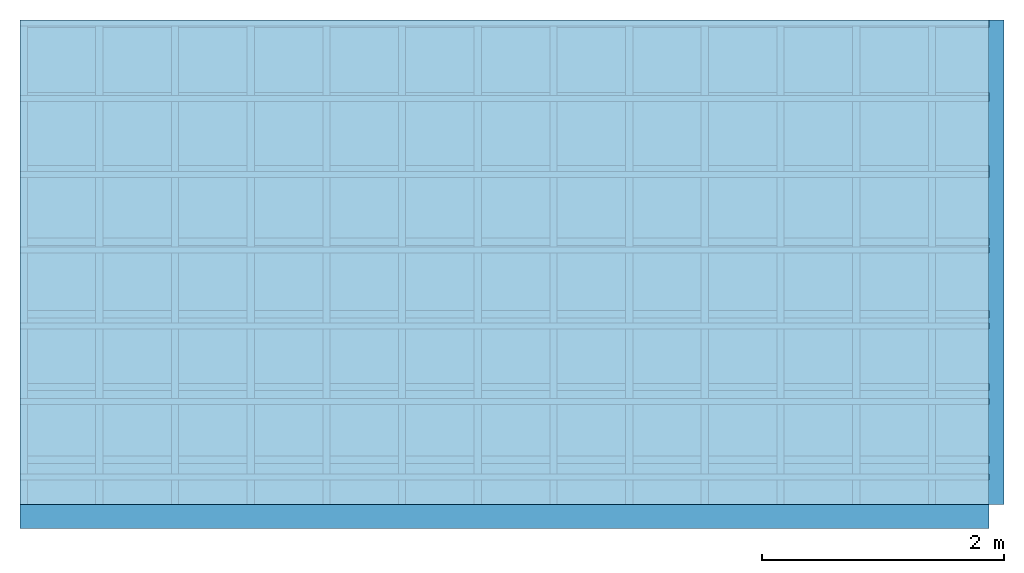
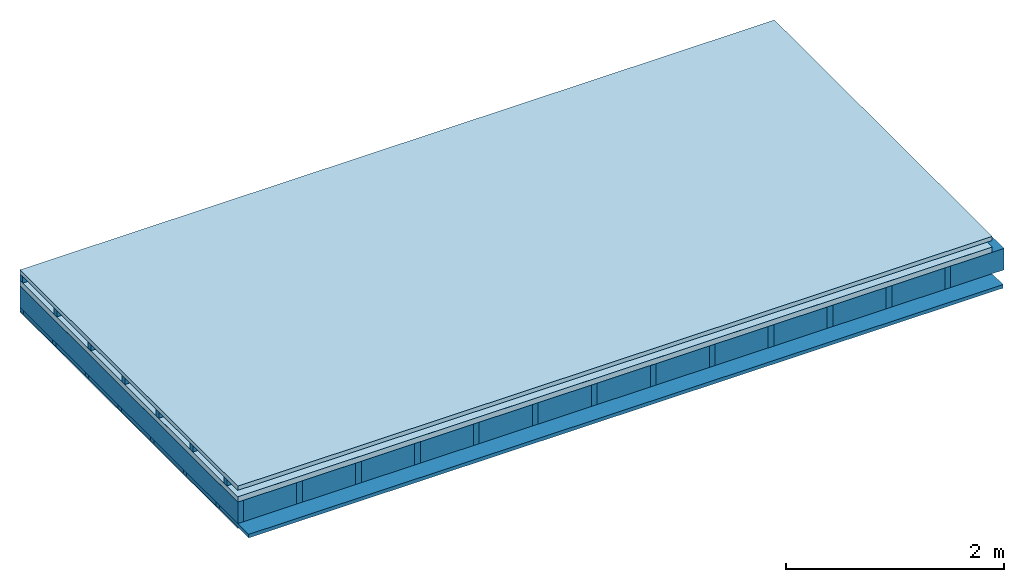
# One storey: 5 members, 4 plates, 1 element without a shape of its own.
"""IFC4 building model written with IfcOpenShell, lengths in metres."""

from ifc_helpers import new_model, si_unit, derived_unit, direction, frame, frame_2d, origin, origin_with_axes, place, context, project, spatial, rectangle, extrude, material, layer, layer_set, type_object, element, aggregate, save


model = new_model("IFC4")

# Units and contexts
plan_context = context("Plan", 3, precision=1e-05, world=origin(), true_north=direction((0.0, 1.0)))
model_context = context("Model", 3, precision=1e-05, world=origin(), true_north=direction((0.0, 1.0)))
ifc_project = project(units=[si_unit("LENGTHUNIT", "METRE"), derived_unit("SOUNDPRESSUREUNIT", [(si_unit("PRESSUREUNIT", "PASCAL", prefix="MICRO"), 0)]), si_unit("ENERGYUNIT", "JOULE", prefix="MEGA"), si_unit("MASSUNIT", "GRAM", prefix="KILO"), derived_unit("THERMALTRANSMITTANCEUNIT", [(si_unit("POWERUNIT", "WATT"), 1), (si_unit("AREAUNIT", "SQUARE_METRE"), -1), (si_unit("THERMODYNAMICTEMPERATUREUNIT", "KELVIN"), -1)]), derived_unit("AREADENSITYUNIT", [(si_unit("MASSUNIT", "GRAM", prefix="KILO"), 1), (si_unit("AREAUNIT", "SQUARE_METRE"), -1)]), derived_unit("USERDEFINED", [(si_unit("ENERGYUNIT", "JOULE", prefix="MEGA"), 1), (si_unit("AREAUNIT", "SQUARE_METRE"), -1)])], contexts=[plan_context, model_context])

# Site, building, storey
site = spatial("IfcSite", under=ifc_project)
building_placement = place(None, origin())
building = spatial("IfcBuilding", under=site, at=building_placement)
storey_placement = place(building_placement, origin())
storey = spatial("IfcBuildingStorey", under=building, at=storey_placement)

# Slab, members, plates
ifc_material_1 = material(Name="Roof tiles", Category="03.015")
ifc_layer_1 = layer(ifc_material_1, 0.047, Name="Roofing")
ifc_layer_2 = layer(None, 0.072, Name="Battens / profiles")
ifc_material_2 = material(Name="Roofing underlay", Category="09.008")
ifc_layer_3 = layer(ifc_material_2, 0.00018, Name="Under the roof")
ifc_material_3 = material(Category="10.009")
ifc_layer_4 = layer(ifc_material_3, 0.06, Name="Exterior insulation layer 1")
ifc_material_4 = material(Name="no composite action")
ifc_layer_5 = layer(ifc_material_4, 0.0, Name="Bond")
ifc_layer_6 = layer(None, 0.24, Name="Supporting structure")
ifc_material_5 = material(Name="of the art")
ifc_layer_7 = layer(ifc_material_5, 0.0, Name="Bond")
ifc_layer_8 = layer(None, 0.04, Name="Battens / profiles")
ifc_material_6 = material(Category="03.007")
ifc_layer_9 = layer(ifc_material_6, 0.015, Name="Covering below 1st layer")
ifc_material_7 = material(Name="Glued joints")
ifc_layer_10 = layer(ifc_material_7, 0.0, Name="Surface below")
ifc_layer_set = layer_set([ifc_layer_1, ifc_layer_2, ifc_layer_3, ifc_layer_4, ifc_layer_5, ifc_layer_6, ifc_layer_7, ifc_layer_8, ifc_layer_9, ifc_layer_10])
slab_type = type_object("IfcSlabType", Name="E0120", PredefinedType="NOTDEFINED", material=ifc_layer_set)
slab_placement = place(None, frame((0.0, 0.0, 0.0), z_axis=(0.0, 0.0, -1.0), x_axis=(1.0, 0.0, 0.0)))
slab = element("IfcSlab", 1, at=slab_placement, inside=storey, type_object=slab_type, material=ifc_layer_set, Name="Slab #1")
ifc_material_8 = material()
member_1_placement = place(slab_placement, origin())
member_1 = element("IfcMember", 2, at=member_1_placement, material=ifc_material_8, Name="Battens / profiles", context=plan_context, shape_type="SweptSolid", body=[
    extrude(rectangle(XDim=0.05, YDim=0.072, at=frame_2d((0.025, 0.036), x_axis=(1.0, 0.0))), frame((0.0, 0.0, 0.047), z_axis=(1.0, 0.0, 0.0), x_axis=(0.0, 1.0, 0.0)), (0.0, 0.0, 1.0), 8.0),
    extrude(rectangle(XDim=0.05, YDim=0.072, at=frame_2d((0.025, 0.036), x_axis=(1.0, 0.0))), frame((0.0, 0.625, 0.047), z_axis=(1.0, 0.0, 0.0), x_axis=(0.0, 1.0, 0.0)), (0.0, 0.0, 1.0), 8.0),
    extrude(rectangle(XDim=0.05, YDim=0.072, at=frame_2d((0.025, 0.036), x_axis=(1.0, 0.0))), frame((0.0, 1.25, 0.047), z_axis=(1.0, 0.0, 0.0), x_axis=(0.0, 1.0, 0.0)), (0.0, 0.0, 1.0), 8.0),
    extrude(rectangle(XDim=0.05, YDim=0.072, at=frame_2d((0.025, 0.036), x_axis=(1.0, 0.0))), frame((0.0, 1.875, 0.047), z_axis=(1.0, 0.0, 0.0), x_axis=(0.0, 1.0, 0.0)), (0.0, 0.0, 1.0), 8.0),
    extrude(rectangle(XDim=0.05, YDim=0.072, at=frame_2d((0.025, 0.036), x_axis=(1.0, 0.0))), frame((0.0, 2.5, 0.047), z_axis=(1.0, 0.0, 0.0), x_axis=(0.0, 1.0, 0.0)), (0.0, 0.0, 1.0), 8.0),
    extrude(rectangle(XDim=0.05, YDim=0.072, at=frame_2d((0.025, 0.036), x_axis=(1.0, 0.0))), frame((0.0, 3.125, 0.047), z_axis=(1.0, 0.0, 0.0), x_axis=(0.0, 1.0, 0.0)), (0.0, 0.0, 1.0), 8.0),
    extrude(rectangle(XDim=0.05, YDim=0.072, at=frame_2d((0.025, 0.036), x_axis=(1.0, 0.0))), frame((0.0, 3.75, 0.047), z_axis=(1.0, 0.0, 0.0), x_axis=(0.0, 1.0, 0.0)), (0.0, 0.0, 1.0), 8.0),
])
ifc_material_9 = material()
member_2_placement = place(slab_placement, origin())
member_2 = element("IfcMember", 3, at=member_2_placement, material=ifc_material_9, Name="Supporting structure", context=plan_context, shape_type="SweptSolid", body=[
    extrude(rectangle(XDim=0.06, YDim=0.24, at=frame_2d((0.03, 0.12), x_axis=(1.0, 0.0))), frame((0.0, 4.0, 0.17918), z_axis=(0.0, -1.0, 0.0), x_axis=(1.0, 0.0, 0.0)), (0.0, 0.0, 1.0), 4.0),
    extrude(rectangle(XDim=0.06, YDim=0.24, at=frame_2d((0.03, 0.12), x_axis=(1.0, 0.0))), frame((0.625, 4.0, 0.17918), z_axis=(0.0, -1.0, 0.0), x_axis=(1.0, 0.0, 0.0)), (0.0, 0.0, 1.0), 4.0),
    extrude(rectangle(XDim=0.06, YDim=0.24, at=frame_2d((0.03, 0.12), x_axis=(1.0, 0.0))), frame((1.25, 4.0, 0.17918), z_axis=(0.0, -1.0, 0.0), x_axis=(1.0, 0.0, 0.0)), (0.0, 0.0, 1.0), 4.0),
    extrude(rectangle(XDim=0.06, YDim=0.24, at=frame_2d((0.03, 0.12), x_axis=(1.0, 0.0))), frame((1.875, 4.0, 0.17918), z_axis=(0.0, -1.0, 0.0), x_axis=(1.0, 0.0, 0.0)), (0.0, 0.0, 1.0), 4.0),
    extrude(rectangle(XDim=0.06, YDim=0.24, at=frame_2d((0.03, 0.12), x_axis=(1.0, 0.0))), frame((2.5, 4.0, 0.17918), z_axis=(0.0, -1.0, 0.0), x_axis=(1.0, 0.0, 0.0)), (0.0, 0.0, 1.0), 4.0),
    extrude(rectangle(XDim=0.06, YDim=0.24, at=frame_2d((0.03, 0.12), x_axis=(1.0, 0.0))), frame((3.125, 4.0, 0.17918), z_axis=(0.0, -1.0, 0.0), x_axis=(1.0, 0.0, 0.0)), (0.0, 0.0, 1.0), 4.0),
    extrude(rectangle(XDim=0.06, YDim=0.24, at=frame_2d((0.03, 0.12), x_axis=(1.0, 0.0))), frame((3.75, 4.0, 0.17918), z_axis=(0.0, -1.0, 0.0), x_axis=(1.0, 0.0, 0.0)), (0.0, 0.0, 1.0), 4.0),
    extrude(rectangle(XDim=0.06, YDim=0.24, at=frame_2d((0.03, 0.12), x_axis=(1.0, 0.0))), frame((4.375, 4.0, 0.17918), z_axis=(0.0, -1.0, 0.0), x_axis=(1.0, 0.0, 0.0)), (0.0, 0.0, 1.0), 4.0),
    extrude(rectangle(XDim=0.06, YDim=0.24, at=frame_2d((0.03, 0.12), x_axis=(1.0, 0.0))), frame((5.0, 4.0, 0.17918), z_axis=(0.0, -1.0, 0.0), x_axis=(1.0, 0.0, 0.0)), (0.0, 0.0, 1.0), 4.0),
    extrude(rectangle(XDim=0.06, YDim=0.24, at=frame_2d((0.03, 0.12), x_axis=(1.0, 0.0))), frame((5.625, 4.0, 0.17918), z_axis=(0.0, -1.0, 0.0), x_axis=(1.0, 0.0, 0.0)), (0.0, 0.0, 1.0), 4.0),
    extrude(rectangle(XDim=0.06, YDim=0.24, at=frame_2d((0.03, 0.12), x_axis=(1.0, 0.0))), frame((6.25, 4.0, 0.17918), z_axis=(0.0, -1.0, 0.0), x_axis=(1.0, 0.0, 0.0)), (0.0, 0.0, 1.0), 4.0),
    extrude(rectangle(XDim=0.06, YDim=0.24, at=frame_2d((0.03, 0.12), x_axis=(1.0, 0.0))), frame((6.875, 4.0, 0.17918), z_axis=(0.0, -1.0, 0.0), x_axis=(1.0, 0.0, 0.0)), (0.0, 0.0, 1.0), 4.0),
    extrude(rectangle(XDim=0.06, YDim=0.24, at=frame_2d((0.03, 0.12), x_axis=(1.0, 0.0))), frame((7.5, 4.0, 0.17918), z_axis=(0.0, -1.0, 0.0), x_axis=(1.0, 0.0, 0.0)), (0.0, 0.0, 1.0), 4.0),
])
ifc_material_10 = material()
member_3_placement = place(slab_placement, origin())
member_3 = element("IfcMember", 4, at=member_3_placement, material=ifc_material_10, Name="Cavity", context=plan_context, shape_type="SweptSolid", body=[
    extrude(rectangle(XDim=0.565, YDim=0.24, at=frame_2d((0.2825, 0.12), x_axis=(1.0, 0.0))), frame((0.06, 4.0, 0.17918), z_axis=(0.0, -1.0, 0.0), x_axis=(1.0, 0.0, 0.0)), (0.0, 0.0, 1.0), 4.0),
    extrude(rectangle(XDim=0.565, YDim=0.24, at=frame_2d((0.2825, 0.12), x_axis=(1.0, 0.0))), frame((0.685, 4.0, 0.17918), z_axis=(0.0, -1.0, 0.0), x_axis=(1.0, 0.0, 0.0)), (0.0, 0.0, 1.0), 4.0),
    extrude(rectangle(XDim=0.565, YDim=0.24, at=frame_2d((0.2825, 0.12), x_axis=(1.0, 0.0))), frame((1.31, 4.0, 0.17918), z_axis=(0.0, -1.0, 0.0), x_axis=(1.0, 0.0, 0.0)), (0.0, 0.0, 1.0), 4.0),
    extrude(rectangle(XDim=0.565, YDim=0.24, at=frame_2d((0.2825, 0.12), x_axis=(1.0, 0.0))), frame((1.935, 4.0, 0.17918), z_axis=(0.0, -1.0, 0.0), x_axis=(1.0, 0.0, 0.0)), (0.0, 0.0, 1.0), 4.0),
    extrude(rectangle(XDim=0.565, YDim=0.24, at=frame_2d((0.2825, 0.12), x_axis=(1.0, 0.0))), frame((2.56, 4.0, 0.17918), z_axis=(0.0, -1.0, 0.0), x_axis=(1.0, 0.0, 0.0)), (0.0, 0.0, 1.0), 4.0),
    extrude(rectangle(XDim=0.565, YDim=0.24, at=frame_2d((0.2825, 0.12), x_axis=(1.0, 0.0))), frame((3.185, 4.0, 0.17918), z_axis=(0.0, -1.0, 0.0), x_axis=(1.0, 0.0, 0.0)), (0.0, 0.0, 1.0), 4.0),
    extrude(rectangle(XDim=0.565, YDim=0.24, at=frame_2d((0.2825, 0.12), x_axis=(1.0, 0.0))), frame((3.81, 4.0, 0.17918), z_axis=(0.0, -1.0, 0.0), x_axis=(1.0, 0.0, 0.0)), (0.0, 0.0, 1.0), 4.0),
    extrude(rectangle(XDim=0.565, YDim=0.24, at=frame_2d((0.2825, 0.12), x_axis=(1.0, 0.0))), frame((4.435, 4.0, 0.17918), z_axis=(0.0, -1.0, 0.0), x_axis=(1.0, 0.0, 0.0)), (0.0, 0.0, 1.0), 4.0),
    extrude(rectangle(XDim=0.565, YDim=0.24, at=frame_2d((0.2825, 0.12), x_axis=(1.0, 0.0))), frame((5.06, 4.0, 0.17918), z_axis=(0.0, -1.0, 0.0), x_axis=(1.0, 0.0, 0.0)), (0.0, 0.0, 1.0), 4.0),
    extrude(rectangle(XDim=0.565, YDim=0.24, at=frame_2d((0.2825, 0.12), x_axis=(1.0, 0.0))), frame((5.685, 4.0, 0.17918), z_axis=(0.0, -1.0, 0.0), x_axis=(1.0, 0.0, 0.0)), (0.0, 0.0, 1.0), 4.0),
    extrude(rectangle(XDim=0.565, YDim=0.24, at=frame_2d((0.2825, 0.12), x_axis=(1.0, 0.0))), frame((6.31, 4.0, 0.17918), z_axis=(0.0, -1.0, 0.0), x_axis=(1.0, 0.0, 0.0)), (0.0, 0.0, 1.0), 4.0),
    extrude(rectangle(XDim=0.565, YDim=0.24, at=frame_2d((0.2825, 0.12), x_axis=(1.0, 0.0))), frame((6.935, 4.0, 0.17918), z_axis=(0.0, -1.0, 0.0), x_axis=(1.0, 0.0, 0.0)), (0.0, 0.0, 1.0), 4.0),
    extrude(rectangle(XDim=0.565, YDim=0.24, at=frame_2d((0.2825, 0.12), x_axis=(1.0, 0.0))), frame((7.56, 4.0, 0.17918), z_axis=(0.0, -1.0, 0.0), x_axis=(1.0, 0.0, 0.0)), (0.0, 0.0, 1.0), 4.0),
])
ifc_material_11 = material()
member_4_placement = place(slab_placement, origin())
member_4 = element("IfcMember", 5, at=member_4_placement, material=ifc_material_11, Name="Battens / profiles", context=plan_context, shape_type="SweptSolid", body=[
    extrude(rectangle(XDim=0.06, YDim=0.04, at=frame_2d((0.03, 0.02), x_axis=(1.0, 0.0))), frame((0.0, 0.0, 0.41918), z_axis=(1.0, 0.0, 0.0), x_axis=(0.0, 1.0, 0.0)), (0.0, 0.0, 1.0), 8.0),
    extrude(rectangle(XDim=0.06, YDim=0.04, at=frame_2d((0.03, 0.02), x_axis=(1.0, 0.0))), frame((0.0, 0.6, 0.41918), z_axis=(1.0, 0.0, 0.0), x_axis=(0.0, 1.0, 0.0)), (0.0, 0.0, 1.0), 8.0),
    extrude(rectangle(XDim=0.06, YDim=0.04, at=frame_2d((0.03, 0.02), x_axis=(1.0, 0.0))), frame((0.0, 1.2, 0.41918), z_axis=(1.0, 0.0, 0.0), x_axis=(0.0, 1.0, 0.0)), (0.0, 0.0, 1.0), 8.0),
    extrude(rectangle(XDim=0.06, YDim=0.04, at=frame_2d((0.03, 0.02), x_axis=(1.0, 0.0))), frame((0.0, 1.8, 0.41918), z_axis=(1.0, 0.0, 0.0), x_axis=(0.0, 1.0, 0.0)), (0.0, 0.0, 1.0), 8.0),
    extrude(rectangle(XDim=0.06, YDim=0.04, at=frame_2d((0.03, 0.02), x_axis=(1.0, 0.0))), frame((0.0, 2.4, 0.41918), z_axis=(1.0, 0.0, 0.0), x_axis=(0.0, 1.0, 0.0)), (0.0, 0.0, 1.0), 8.0),
    extrude(rectangle(XDim=0.06, YDim=0.04, at=frame_2d((0.03, 0.02), x_axis=(1.0, 0.0))), frame((0.0, 3.0, 0.41918), z_axis=(1.0, 0.0, 0.0), x_axis=(0.0, 1.0, 0.0)), (0.0, 0.0, 1.0), 8.0),
    extrude(rectangle(XDim=0.06, YDim=0.04, at=frame_2d((0.03, 0.02), x_axis=(1.0, 0.0))), frame((0.0, 3.6, 0.41918), z_axis=(1.0, 0.0, 0.0), x_axis=(0.0, 1.0, 0.0)), (0.0, 0.0, 1.0), 8.0),
])
ifc_material_12 = material(Name="Mineral wool")
member_5_placement = place(slab_placement, origin())
member_5 = element("IfcMember", 6, at=member_5_placement, material=ifc_material_12, Name="Cavity", context=plan_context, shape_type="SweptSolid", body=[
    extrude(rectangle(XDim=0.54, YDim=0.04, at=frame_2d((0.27, 0.02), x_axis=(1.0, 0.0))), frame((0.0, 0.06, 0.41918), z_axis=(1.0, 0.0, 0.0), x_axis=(0.0, 1.0, 0.0)), (0.0, 0.0, 1.0), 8.0),
    extrude(rectangle(XDim=0.54, YDim=0.04, at=frame_2d((0.27, 0.02), x_axis=(1.0, 0.0))), frame((0.0, 0.66, 0.41918), z_axis=(1.0, 0.0, 0.0), x_axis=(0.0, 1.0, 0.0)), (0.0, 0.0, 1.0), 8.0),
    extrude(rectangle(XDim=0.54, YDim=0.04, at=frame_2d((0.27, 0.02), x_axis=(1.0, 0.0))), frame((0.0, 1.26, 0.41918), z_axis=(1.0, 0.0, 0.0), x_axis=(0.0, 1.0, 0.0)), (0.0, 0.0, 1.0), 8.0),
    extrude(rectangle(XDim=0.54, YDim=0.04, at=frame_2d((0.27, 0.02), x_axis=(1.0, 0.0))), frame((0.0, 1.86, 0.41918), z_axis=(1.0, 0.0, 0.0), x_axis=(0.0, 1.0, 0.0)), (0.0, 0.0, 1.0), 8.0),
    extrude(rectangle(XDim=0.54, YDim=0.04, at=frame_2d((0.27, 0.02), x_axis=(1.0, 0.0))), frame((0.0, 2.46, 0.41918), z_axis=(1.0, 0.0, 0.0), x_axis=(0.0, 1.0, 0.0)), (0.0, 0.0, 1.0), 8.0),
    extrude(rectangle(XDim=0.54, YDim=0.04, at=frame_2d((0.27, 0.02), x_axis=(1.0, 0.0))), frame((0.0, 3.06, 0.41918), z_axis=(1.0, 0.0, 0.0), x_axis=(0.0, 1.0, 0.0)), (0.0, 0.0, 1.0), 8.0),
    extrude(rectangle(XDim=0.54, YDim=0.04, at=frame_2d((0.27, 0.02), x_axis=(1.0, 0.0))), frame((0.0, 3.66, 0.41918), z_axis=(1.0, 0.0, 0.0), x_axis=(0.0, 1.0, 0.0)), (0.0, 0.0, 1.0), 8.0),
])
plate_1_placement = place(slab_placement, origin())
plate_1 = element("IfcPlate", 7, at=plate_1_placement, material=ifc_material_1, Name="Roofing", context=plan_context, shape_type="SweptSolid", body=[
    extrude(rectangle(XDim=8.0, YDim=4.0, at=frame_2d((4.0, 2.0), x_axis=(1.0, 0.0))), origin_with_axes(), (0.0, 0.0, 1.0), 0.047),
])
plate_2_placement = place(slab_placement, origin())
plate_2 = element("IfcPlate", 8, at=plate_2_placement, material=ifc_material_2, Name="Under the roof", context=plan_context, shape_type="SweptSolid", body=[
    extrude(rectangle(XDim=8.0, YDim=4.0, at=frame_2d((4.0, 2.0), x_axis=(1.0, 0.0))), frame((0.0, 0.0, 0.119), z_axis=(0.0, 0.0, 1.0), x_axis=(1.0, 0.0, 0.0)), (0.0, 0.0, 1.0), 0.00018),
])
plate_3_placement = place(slab_placement, origin())
plate_3 = element("IfcPlate", 9, at=plate_3_placement, material=ifc_material_3, Name="Exterior insulation layer 1", context=plan_context, shape_type="SweptSolid", body=[
    extrude(rectangle(XDim=8.0, YDim=4.0, at=frame_2d((4.0, 2.0), x_axis=(1.0, 0.0))), frame((0.0, 0.0, 0.11918), z_axis=(0.0, 0.0, 1.0), x_axis=(1.0, 0.0, 0.0)), (0.0, 0.0, 1.0), 0.06),
])
plate_4_placement = place(slab_placement, origin())
plate_4 = element("IfcPlate", 10, at=plate_4_placement, material=ifc_material_6, Name="Covering below 1st layer", context=plan_context, shape_type="SweptSolid", body=[
    extrude(rectangle(XDim=8.0, YDim=4.0, at=frame_2d((4.0, 2.0), x_axis=(1.0, 0.0))), frame((0.0, 0.0, 0.45918), z_axis=(0.0, 0.0, 1.0), x_axis=(1.0, 0.0, 0.0)), (0.0, 0.0, 1.0), 0.015),
])
aggregate(slab, [plate_1, member_1, plate_2, plate_3, member_2, member_3, member_4, member_5, plate_4])

save(model, "model.ifc")
